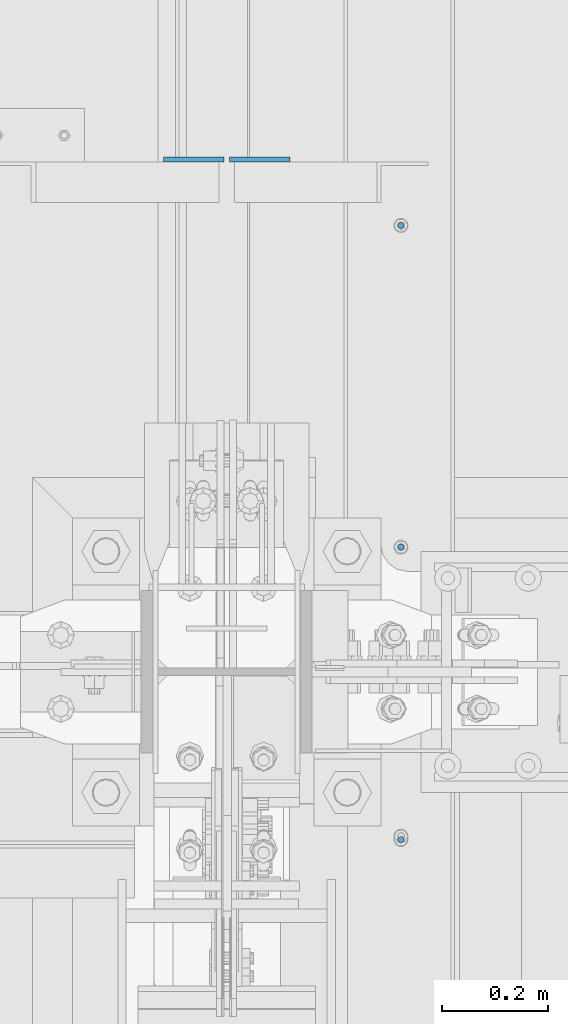
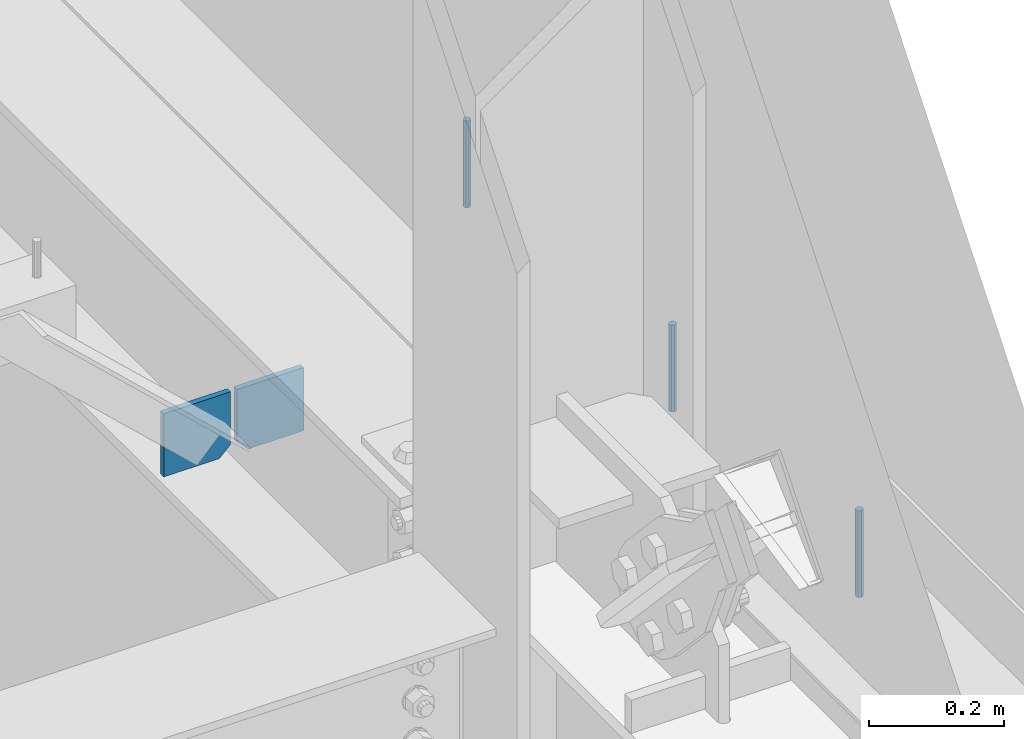
# One storey, part 559 of 1179: 5 columns, 2 elements without a shape of their own.
"""IFC2X3 building model written with IfcOpenShell, lengths in millimetres."""

from ifc_helpers import new_model, si_unit, frame, origin_with_axes, place, context, subcontext, project, spatial, faceted_brep, material, type_object, element, aggregate, save


model = new_model("IFC2X3")

# Units and contexts
model_context = context("Model", 3, precision=1e-05, world=origin_with_axes())
body_context = subcontext(model_context, "Body", "Model", "MODEL_VIEW")
ifc_project = project(units=[si_unit("LENGTHUNIT", "METRE", prefix="MILLI"), si_unit("AREAUNIT", "SQUARE_METRE"), si_unit("VOLUMEUNIT", "CUBIC_METRE"), si_unit("MASSUNIT", "GRAM", prefix="KILO"), si_unit("TIMEUNIT", "SECOND"), si_unit("PLANEANGLEUNIT", "RADIAN"), si_unit("SOLIDANGLEUNIT", "STERADIAN"), si_unit("THERMODYNAMICTEMPERATUREUNIT", "DEGREE_CELSIUS"), si_unit("LUMINOUSINTENSITYUNIT", "LUMEN")], contexts=[model_context])

# Site, building, storey
site_placement = place(None, origin_with_axes())
site = spatial("IfcSite", under=ifc_project, at=site_placement, CompositionType="ELEMENT")
building_placement = place(site_placement, origin_with_axes())
building = spatial("IfcBuilding", under=site, at=building_placement, Name="Undefined", CompositionType="ELEMENT")
storey_placement = place(building_placement, origin_with_axes())
storey = spatial("IfcBuildingStorey", under=building, at=storey_placement, Name="Undefined", CompositionType="ELEMENT", Elevation=0.0)

# Assembly, columns
assembly_1_placement = place(storey_placement, origin_with_axes())
assembly_1 = element("IfcElementAssembly", 1, at=assembly_1_placement, inside=storey, Name="BEAM", AssemblyPlace="NOTDEFINED", PredefinedType="RIGID_FRAME")
ifc_material_1 = material(Name="STEEL/A36")
column_type_1 = type_object("IfcColumnType", PredefinedType="NOTDEFINED")
column_1_placement = place(assembly_1_placement, frame((24245.09375, 35362.35625, 3702.05), z_axis=(1.0, 0.0, 0.0), x_axis=(0.0, 0.0, 1.0)))
column_1 = element("IfcColumn", 2, at=column_1_placement, type_object=column_type_1, material=ifc_material_1, Name="PLATE", context=body_context, shape_type="Brep", body=[
    faceted_brep([(19.0500000000002, 4.76250000000073, 57.1500000000015), (0.0, 4.76250000000073, 38.0999999999985), (0.0, -4.76250000000073, 38.0999999999985), (19.0500000000002, -4.76250000000073, 57.1500000000015), (114.300000000001, 4.76250000000073, 57.1500000000015), (114.300000000001, 4.76250000000073, -57.1500000000015), (0.0, 4.76250000000073, -57.1500000000015), (114.300000000001, -4.76250000000073, 57.1500000000015), (0.0, -4.76250000000073, -57.1500000000015), (114.300000000001, -4.76250000000073, -57.1500000000015)], [[[0, 1, 2, 3]], [[4, 5, 6, 1, 0]], [[7, 4, 0, 3]], [[8, 9, 7, 3, 2]], [[8, 6, 5, 9]], [[7, 9, 5, 4]], [[6, 8, 2, 1]]]),
])
column_2_placement = place(assembly_1_placement, frame((24370.50625, 35362.35625, 3702.05), z_axis=(-1.0, 0.0, 0.0), x_axis=(0.0, 0.0, 1.0)))
column_2 = element("IfcColumn", 3, at=column_2_placement, type_object=column_type_1, material=ifc_material_1, Name="PLATE", context=body_context, shape_type="Brep", body=[
    faceted_brep([(19.0500000000002, 4.76250000000073, 57.1500000000015), (0.0, 4.76250000000073, 38.0999999999985), (0.0, -4.76250000000073, 38.0999999999985), (19.0500000000002, -4.76250000000073, 57.1500000000015), (114.300000000001, 4.76250000000073, 57.1500000000015), (114.300000000001, 4.76250000000073, -57.1500000000015), (0.0, 4.76250000000073, -57.1500000000015), (114.300000000001, -4.76250000000073, 57.1500000000015), (0.0, -4.76250000000073, -57.1500000000015), (114.300000000001, -4.76250000000073, -57.1500000000015)], [[[0, 1, 2, 3]], [[4, 5, 6, 1, 0]], [[7, 4, 0, 3]], [[8, 9, 7, 3, 2]], [[8, 6, 5, 9]], [[7, 9, 5, 4]], [[6, 8, 2, 1]]]),
])
ifc_material_2 = material(Name="STEEL/A307")
column_type_2 = type_object("IfcColumnType", PredefinedType="NOTDEFINED")
column_3_placement = place(assembly_1_placement, frame((24638.0003519435, 35237.7375, 4108.45), z_axis=(0.0, 1.0, 0.0), x_axis=(0.0, 0.0, 1.0)))
column_3 = element("IfcColumn", 4, at=column_3_placement, type_object=column_type_2, material=ifc_material_2, Name="THREADED ROD", context=body_context, shape_type="Brep", body=[
    faceted_brep([(0.0, -6.34999999999854, 0.0), (0.0, -4.49012806053361, -4.49012806053452), (157.162499999999, -4.49012806053361, -4.49012806053361), (157.162499999999, -6.34999999999854, 0.0), (0.0, 0.0, -6.34999999999991), (157.162499999999, 0.0, -6.34999999999854), (0.0, 4.49012806053361, -4.49012806053452), (157.162499999999, 4.49012806053361, -4.49012806053361), (0.0, 6.34999999999854, 0.0), (157.162499999999, 6.34999999999854, 0.0), (0.0, 4.49012806053361, 4.49012806053452), (157.162499999999, 4.49012806053361, 4.49012806053361), (0.0, 0.0, 6.34999999999991), (157.162499999999, 0.0, 6.34999999999854), (0.0, -4.49012806053361, 4.49012806053452), (157.162499999999, -4.49012806053361, 4.49012806053361)], [[[0, 1, 2, 3]], [[1, 4, 5, 2]], [[4, 6, 7, 5]], [[6, 8, 9, 7]], [[8, 10, 11, 9]], [[10, 12, 13, 11]], [[12, 14, 15, 13]], [[14, 0, 3, 15]], [[5, 7, 9, 11, 13, 15, 3, 2]], [[14, 12, 10, 8, 6, 4, 1, 0]]]),
])
column_4_placement = place(assembly_1_placement, frame((24638.0003519435, 34628.1375, 4108.45), z_axis=(0.0, 1.0, 0.0), x_axis=(0.0, 0.0, 1.0)))
column_4 = element("IfcColumn", 5, at=column_4_placement, type_object=column_type_2, material=ifc_material_2, Name="THREADED ROD", context=body_context, shape_type="Brep", body=[
    faceted_brep([(0.0, -6.34999999999854, 0.0), (0.0, -4.49012806053361, -4.49012806053452), (157.162499999999, -4.49012806053361, -4.49012806053361), (157.162499999999, -6.34999999999854, 0.0), (0.0, 0.0, -6.34999999999991), (157.162499999999, 0.0, -6.34999999999854), (0.0, 4.49012806053361, -4.49012806053452), (157.162499999999, 4.49012806053361, -4.49012806053361), (0.0, 6.34999999999854, 0.0), (157.162499999999, 6.34999999999854, 0.0), (0.0, 4.49012806053361, 4.49012806053452), (157.162499999999, 4.49012806053361, 4.49012806053361), (0.0, 0.0, 6.34999999999991), (157.162499999999, 0.0, 6.34999999999854), (0.0, -4.49012806053361, 4.49012806053452), (157.162499999999, -4.49012806053361, 4.49012806053361)], [[[0, 1, 2, 3]], [[1, 4, 5, 2]], [[4, 6, 7, 5]], [[6, 8, 9, 7]], [[8, 10, 11, 9]], [[10, 12, 13, 11]], [[12, 14, 15, 13]], [[14, 0, 3, 15]], [[5, 7, 9, 11, 13, 15, 3, 2]], [[14, 12, 10, 8, 6, 4, 1, 0]]]),
])
aggregate(assembly_1, [column_3, column_4, column_1, column_2])

# Assembly, column
assembly_2_placement = place(storey_placement, origin_with_axes())
assembly_2 = element("IfcElementAssembly", 6, at=assembly_2_placement, inside=storey, Name="BEAM", AssemblyPlace="NOTDEFINED", PredefinedType="RIGID_FRAME")
column_5_placement = place(assembly_2_placement, frame((24638.0, 34074.10025, 4108.45), z_axis=(0.0, 1.0, 0.0), x_axis=(0.0, 0.0, 1.0)))
column_5 = element("IfcColumn", 7, at=column_5_placement, type_object=column_type_2, material=ifc_material_2, Name="THREADED ROD", context=body_context, shape_type="Brep", body=[
    faceted_brep([(0.0, -6.34999999999854, 0.0), (0.0, -4.49012806053361, -4.49012806053452), (157.162499999999, -4.49012806053361, -4.49012806053361), (157.162499999999, -6.34999999999854, 0.0), (0.0, 0.0, -6.34999999999991), (157.162499999999, 0.0, -6.34999999999854), (0.0, 4.49012806053361, -4.49012806053452), (157.162499999999, 4.49012806053361, -4.49012806053361), (0.0, 6.34999999999854, 0.0), (157.162499999999, 6.34999999999854, 0.0), (0.0, 4.49012806053361, 4.49012806053452), (157.162499999999, 4.49012806053361, 4.49012806053361), (0.0, 0.0, 6.34999999999991), (157.162499999999, 0.0, 6.34999999999854), (0.0, -4.49012806053361, 4.49012806053452), (157.162499999999, -4.49012806053361, 4.49012806053361)], [[[0, 1, 2, 3]], [[1, 4, 5, 2]], [[4, 6, 7, 5]], [[6, 8, 9, 7]], [[8, 10, 11, 9]], [[10, 12, 13, 11]], [[12, 14, 15, 13]], [[14, 0, 3, 15]], [[5, 7, 9, 11, 13, 15, 3, 2]], [[14, 12, 10, 8, 6, 4, 1, 0]]]),
])
aggregate(assembly_2, [column_5])

save(model, "model.ifc")
